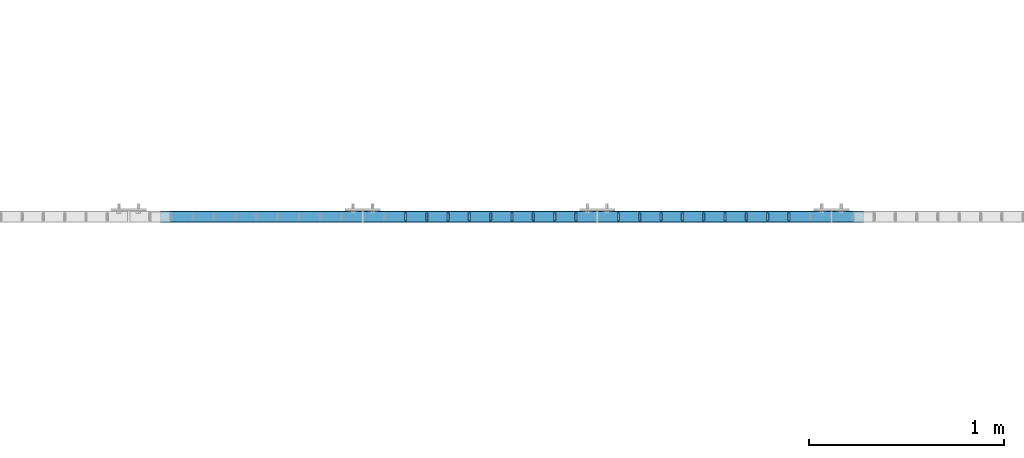
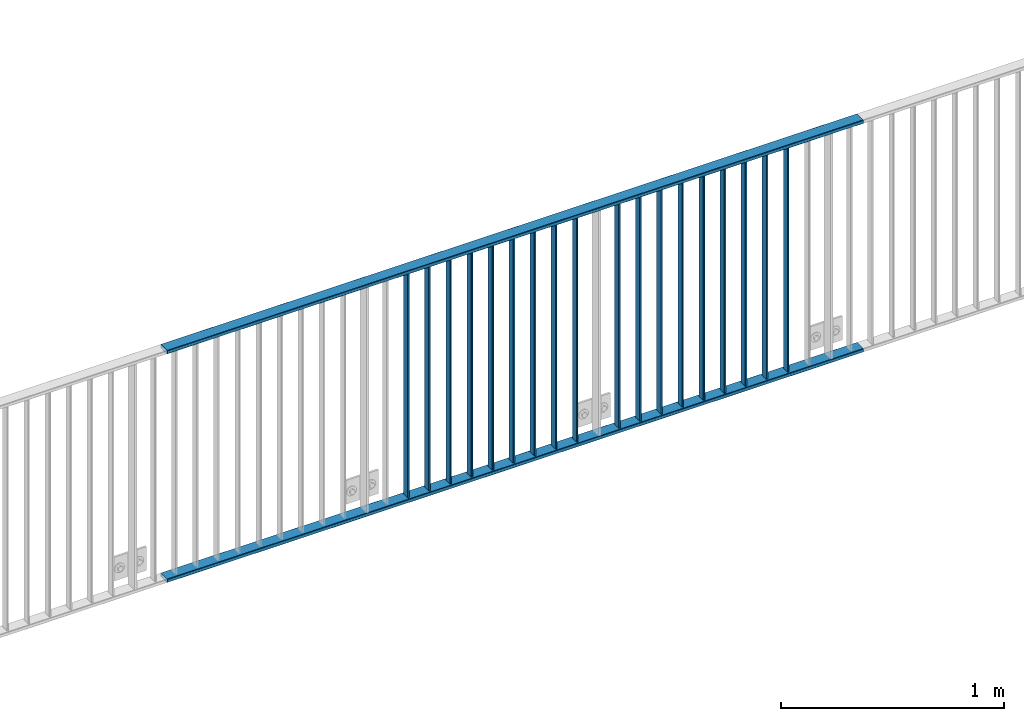
# One storey, part 7 of 156: 20 beams, 1 element without a shape of its own.
"""IFC2X3 building model written with IfcOpenShell, lengths in millimetres."""

from ifc_helpers import new_model, si_unit, frame, origin_with_axes, origin_2d_with_axis, place, context, subcontext, project, spatial, hollow_rectangle, extrude, clip, halfspace, material, type_object, element, aggregate, save


model = new_model("IFC2X3")

# Units and contexts
model_context = context("Model", 3, precision=1e-05, world=origin_with_axes())
body_context = subcontext(model_context, "Body", "Model", "MODEL_VIEW")
ifc_project = project(units=[si_unit("LENGTHUNIT", "METRE", prefix="MILLI"), si_unit("AREAUNIT", "SQUARE_METRE"), si_unit("VOLUMEUNIT", "CUBIC_METRE"), si_unit("MASSUNIT", "GRAM", prefix="KILO"), si_unit("TIMEUNIT", "SECOND"), si_unit("PLANEANGLEUNIT", "RADIAN"), si_unit("SOLIDANGLEUNIT", "STERADIAN"), si_unit("THERMODYNAMICTEMPERATUREUNIT", "DEGREE_CELSIUS"), si_unit("LUMINOUSINTENSITYUNIT", "LUMEN")], contexts=[model_context])

# Site, building, storey
site_placement = place(None, origin_with_axes())
site = spatial("IfcSite", under=ifc_project, at=site_placement, CompositionType="ELEMENT")
building_placement = place(site_placement, origin_with_axes())
building = spatial("IfcBuilding", under=site, at=building_placement, Name="Undefined", CompositionType="ELEMENT")
storey_placement = place(building_placement, origin_with_axes())
storey = spatial("IfcBuildingStorey", under=building, at=storey_placement, Name="Undefined", CompositionType="ELEMENT", Elevation=0.0)

# Assembly, beams
assembly_placement = place(storey_placement, origin_with_axes())
assembly = element("IfcElementAssembly", 1, at=assembly_placement, inside=storey, AssemblyPlace="NOTDEFINED", PredefinedType="RIGID_FRAME")
ifc_material = material(Name="STEEL/S235JR")
beam_type_1 = type_object("IfcBeamType", Name="K60/20/2", PredefinedType="NOTDEFINED")
beam_1_placement = place(assembly_placement, frame((17963.649999999, 10879.9998016357, 2740.0), z_axis=(0.0, 1.0, 0.0), x_axis=(1.0, 0.0, 0.0)))
beam_1 = element("IfcBeam", 2, at=beam_1_placement, type_object=beam_type_1, material=ifc_material, ObjectType="K60/20/2", context=body_context, shape_type="SweptSolid", body=[
    extrude(hollow_rectangle(XDim=20.0, YDim=60.0, WallThickness=2.0, InnerFilletRadius=2.0, OuterFilletRadius=4.0, at=origin_2d_with_axis()), frame((3599.985, 0.0, 0.0), z_axis=(-1.0, 0.0, 0.0), x_axis=(0.0, -1.0, 0.0)), (0.0, 0.0, 1.0), 3599.98),
])
beam_2_placement = place(assembly_placement, frame((17963.6457423371, 10879.9998016358, 3990.0), z_axis=(0.0, 1.0, 0.0), x_axis=(1.0, 0.0, 0.0)))
beam_2 = element("IfcBeam", 3, at=beam_2_placement, type_object=beam_type_1, material=ifc_material, ObjectType="K60/20/2", context=body_context, shape_type="SweptSolid", body=[
    extrude(hollow_rectangle(XDim=20.0, YDim=60.0, WallThickness=2.0, InnerFilletRadius=2.0, OuterFilletRadius=4.0, at=origin_2d_with_axis()), frame((3599.98925766191, 0.0, 0.0), z_axis=(-1.0, 0.0, 0.0), x_axis=(0.0, -1.0, 0.0)), (0.0, 0.0, 1.0), 3599.99),
])
beam_type_2 = type_object("IfcBeamType", Name="K40/10/1.5", PredefinedType="NOTDEFINED")
beam_3_placement = place(assembly_placement, frame((21181.809999999, 10879.9998088346, 3980.00000000003), z_axis=(0.0, 1.0, 0.0), x_axis=(0.0, 0.0, -1.0)))
beam_3 = element("IfcBeam", 4, at=beam_3_placement, type_object=beam_type_2, material=ifc_material, ObjectType="K40/10/1.5", context=body_context, shape_type="Clipping", body=[
    clip(clip(extrude(hollow_rectangle(XDim=10.0, YDim=40.0, WallThickness=1.5, InnerFilletRadius=1.5, OuterFilletRadius=3.0, at=origin_2d_with_axis()), frame((1237.00000000003, 0.0, 0.0), z_axis=(-1.0, 0.0, 0.0), x_axis=(0.0, -1.0, 0.0)), (0.0, 0.0, 1.0), 1244.0), halfspace(frame((1237.00000000003, 4.28697690345871, 47.3348312091512), z_axis=(1.0, 0.0, 0.0), x_axis=(0.0, -0.763991285051099, -0.645226562043109)), False)), halfspace(frame((-6.99999999997453, -4.08341515816574, 47.1651964219527), z_axis=(-1.0, 0.0, 0.0), x_axis=(0.0, 0.763991285051099, -0.645226562043109)), False)),
])
beam_4_placement = place(assembly_placement, frame((21072.719999999, 10879.9998088346, 3980.00000000003), z_axis=(0.0, 1.0, 0.0), x_axis=(0.0, 0.0, -1.0)))
beam_4 = element("IfcBeam", 5, at=beam_4_placement, type_object=beam_type_2, material=ifc_material, ObjectType="K40/10/1.5", context=body_context, shape_type="Clipping", body=[
    clip(clip(extrude(hollow_rectangle(XDim=10.0, YDim=40.0, WallThickness=1.5, InnerFilletRadius=1.5, OuterFilletRadius=3.0, at=origin_2d_with_axis()), frame((1237.00000000003, 0.0, 0.0), z_axis=(-1.0, 0.0, 0.0), x_axis=(0.0, -1.0, 0.0)), (0.0, 0.0, 1.0), 1244.0), halfspace(frame((1237.00000000003, 4.28697690345871, 47.3348312091512), z_axis=(1.0, 0.0, 0.0), x_axis=(0.0, -0.763991285051099, -0.645226562043109)), False)), halfspace(frame((-6.99999999997453, -4.08341515816574, 47.1651964219527), z_axis=(-1.0, 0.0, 0.0), x_axis=(0.0, 0.763991285051099, -0.645226562043109)), False)),
])
beam_5_placement = place(assembly_placement, frame((20963.629999999, 10879.9998088346, 3980.00000000003), z_axis=(0.0, 1.0, 0.0), x_axis=(0.0, 0.0, -1.0)))
beam_5 = element("IfcBeam", 6, at=beam_5_placement, type_object=beam_type_2, material=ifc_material, ObjectType="K40/10/1.5", context=body_context, shape_type="Clipping", body=[
    clip(clip(extrude(hollow_rectangle(XDim=10.0, YDim=40.0, WallThickness=1.5, InnerFilletRadius=1.5, OuterFilletRadius=3.0, at=origin_2d_with_axis()), frame((1237.00000000003, 0.0, 0.0), z_axis=(-1.0, 0.0, 0.0), x_axis=(0.0, -1.0, 0.0)), (0.0, 0.0, 1.0), 1244.0), halfspace(frame((1237.00000000003, 4.28697690345871, 47.3348312091512), z_axis=(1.0, 0.0, 0.0), x_axis=(0.0, -0.763991285051099, -0.645226562043109)), False)), halfspace(frame((-6.99999999997453, -4.08341515816574, 47.1651964219527), z_axis=(-1.0, 0.0, 0.0), x_axis=(0.0, 0.763991285051099, -0.645226562043109)), False)),
])
beam_6_placement = place(assembly_placement, frame((20854.539999999, 10879.9998088346, 3980.00000000003), z_axis=(0.0, 1.0, 0.0), x_axis=(0.0, 0.0, -1.0)))
beam_6 = element("IfcBeam", 7, at=beam_6_placement, type_object=beam_type_2, material=ifc_material, ObjectType="K40/10/1.5", context=body_context, shape_type="Clipping", body=[
    clip(clip(extrude(hollow_rectangle(XDim=10.0, YDim=40.0, WallThickness=1.5, InnerFilletRadius=1.5, OuterFilletRadius=3.0, at=origin_2d_with_axis()), frame((1237.00000000003, 0.0, 0.0), z_axis=(-1.0, 0.0, 0.0), x_axis=(0.0, -1.0, 0.0)), (0.0, 0.0, 1.0), 1244.0), halfspace(frame((1237.00000000003, 4.28697690345871, 47.3348312091512), z_axis=(1.0, 0.0, 0.0), x_axis=(0.0, -0.763991285051099, -0.645226562043109)), False)), halfspace(frame((-6.99999999997453, -4.08341515816574, 47.1651964219527), z_axis=(-1.0, 0.0, 0.0), x_axis=(0.0, 0.763991285051099, -0.645226562043109)), False)),
])
beam_7_placement = place(assembly_placement, frame((20745.449999999, 10879.9998088346, 3980.00000000003), z_axis=(0.0, 1.0, 0.0), x_axis=(0.0, 0.0, -1.0)))
beam_7 = element("IfcBeam", 8, at=beam_7_placement, type_object=beam_type_2, material=ifc_material, ObjectType="K40/10/1.5", context=body_context, shape_type="Clipping", body=[
    clip(clip(extrude(hollow_rectangle(XDim=10.0, YDim=40.0, WallThickness=1.5, InnerFilletRadius=1.5, OuterFilletRadius=3.0, at=origin_2d_with_axis()), frame((1237.00000000003, 0.0, 0.0), z_axis=(-1.0, 0.0, 0.0), x_axis=(0.0, -1.0, 0.0)), (0.0, 0.0, 1.0), 1244.0), halfspace(frame((1237.00000000003, 4.28697690345871, 47.3348312091512), z_axis=(1.0, 0.0, 0.0), x_axis=(0.0, -0.763991285051099, -0.645226562043109)), False)), halfspace(frame((-6.99999999997453, -4.08341515816574, 47.1651964219527), z_axis=(-1.0, 0.0, 0.0), x_axis=(0.0, 0.763991285051099, -0.645226562043109)), False)),
])
beam_8_placement = place(assembly_placement, frame((20636.359999999, 10879.9998088346, 3980.00000000003), z_axis=(0.0, 1.0, 0.0), x_axis=(0.0, 0.0, -1.0)))
beam_8 = element("IfcBeam", 9, at=beam_8_placement, type_object=beam_type_2, material=ifc_material, ObjectType="K40/10/1.5", context=body_context, shape_type="Clipping", body=[
    clip(clip(extrude(hollow_rectangle(XDim=10.0, YDim=40.0, WallThickness=1.5, InnerFilletRadius=1.5, OuterFilletRadius=3.0, at=origin_2d_with_axis()), frame((1237.00000000003, 0.0, 0.0), z_axis=(-1.0, 0.0, 0.0), x_axis=(0.0, -1.0, 0.0)), (0.0, 0.0, 1.0), 1244.0), halfspace(frame((1237.00000000003, 4.28697690345871, 47.3348312091512), z_axis=(1.0, 0.0, 0.0), x_axis=(0.0, -0.763991285051099, -0.645226562043109)), False)), halfspace(frame((-6.99999999997453, -4.08341515816574, 47.1651964219527), z_axis=(-1.0, 0.0, 0.0), x_axis=(0.0, 0.763991285051099, -0.645226562043109)), False)),
])
beam_9_placement = place(assembly_placement, frame((20527.269999999, 10879.9998088346, 3980.00000000003), z_axis=(0.0, 1.0, 0.0), x_axis=(0.0, 0.0, -1.0)))
beam_9 = element("IfcBeam", 10, at=beam_9_placement, type_object=beam_type_2, material=ifc_material, ObjectType="K40/10/1.5", context=body_context, shape_type="Clipping", body=[
    clip(clip(extrude(hollow_rectangle(XDim=10.0, YDim=40.0, WallThickness=1.5, InnerFilletRadius=1.5, OuterFilletRadius=3.0, at=origin_2d_with_axis()), frame((1237.00000000003, 0.0, 0.0), z_axis=(-1.0, 0.0, 0.0), x_axis=(0.0, -1.0, 0.0)), (0.0, 0.0, 1.0), 1244.0), halfspace(frame((1237.00000000003, 4.28697690345871, 47.3348312091512), z_axis=(1.0, 0.0, 0.0), x_axis=(0.0, -0.763991285051099, -0.645226562043109)), False)), halfspace(frame((-6.99999999997453, -4.08341515816574, 47.1651964219527), z_axis=(-1.0, 0.0, 0.0), x_axis=(0.0, 0.763991285051099, -0.645226562043109)), False)),
])
beam_10_placement = place(assembly_placement, frame((20418.179999999, 10879.9998088346, 3980.00000000003), z_axis=(0.0, 1.0, 0.0), x_axis=(0.0, 0.0, -1.0)))
beam_10 = element("IfcBeam", 11, at=beam_10_placement, type_object=beam_type_2, material=ifc_material, ObjectType="K40/10/1.5", context=body_context, shape_type="Clipping", body=[
    clip(clip(extrude(hollow_rectangle(XDim=10.0, YDim=40.0, WallThickness=1.5, InnerFilletRadius=1.5, OuterFilletRadius=3.0, at=origin_2d_with_axis()), frame((1237.00000000003, 0.0, 0.0), z_axis=(-1.0, 0.0, 0.0), x_axis=(0.0, -1.0, 0.0)), (0.0, 0.0, 1.0), 1244.0), halfspace(frame((1237.00000000003, 4.28697690345871, 47.3348312091512), z_axis=(1.0, 0.0, 0.0), x_axis=(0.0, -0.763991285051099, -0.645226562043109)), False)), halfspace(frame((-6.99999999997453, -4.08341515816574, 47.1651964219527), z_axis=(-1.0, 0.0, 0.0), x_axis=(0.0, 0.763991285051099, -0.645226562043109)), False)),
])
beam_11_placement = place(assembly_placement, frame((20309.089999999, 10879.9998088346, 3980.00000000003), z_axis=(0.0, 1.0, 0.0), x_axis=(0.0, 0.0, -1.0)))
beam_11 = element("IfcBeam", 12, at=beam_11_placement, type_object=beam_type_2, material=ifc_material, ObjectType="K40/10/1.5", context=body_context, shape_type="Clipping", body=[
    clip(clip(extrude(hollow_rectangle(XDim=10.0, YDim=40.0, WallThickness=1.5, InnerFilletRadius=1.5, OuterFilletRadius=3.0, at=origin_2d_with_axis()), frame((1237.00000000003, 0.0, 0.0), z_axis=(-1.0, 0.0, 0.0), x_axis=(0.0, -1.0, 0.0)), (0.0, 0.0, 1.0), 1244.0), halfspace(frame((1237.00000000003, 4.20486777192855, 47.2664069333041), z_axis=(1.0, 0.0, 0.0), x_axis=(0.0, -0.763991285051099, -0.645226562043109)), False)), halfspace(frame((-6.99999999997453, -3.90376720472705, 47.0154897941757), z_axis=(-1.0, 0.0, 0.0), x_axis=(0.0, 0.761952806119621, -0.647632551101653)), False)),
])
beam_12_placement = place(assembly_placement, frame((20090.899999999, 10879.9998088346, 3980.00000000003), z_axis=(0.0, 1.0, 0.0), x_axis=(0.0, 0.0, -1.0)))
beam_12 = element("IfcBeam", 13, at=beam_12_placement, type_object=beam_type_2, material=ifc_material, ObjectType="K40/10/1.5", context=body_context, shape_type="Clipping", body=[
    clip(clip(extrude(hollow_rectangle(XDim=10.0, YDim=40.0, WallThickness=1.5, InnerFilletRadius=1.5, OuterFilletRadius=3.0, at=origin_2d_with_axis()), frame((1237.00000000003, 0.0, 0.0), z_axis=(-1.0, 0.0, 0.0), x_axis=(0.0, -1.0, 0.0)), (0.0, 0.0, 1.0), 1244.0), halfspace(frame((1237.00000000003, 4.28697690345871, 47.3348312091512), z_axis=(1.0, 0.0, 0.0), x_axis=(0.0, -0.763991285051099, -0.645226562043109)), False)), halfspace(frame((-6.99999999997453, -4.08341515816574, 47.1651964219527), z_axis=(-1.0, 0.0, 0.0), x_axis=(0.0, 0.763991285051099, -0.645226562043109)), False)),
])
beam_13_placement = place(assembly_placement, frame((19981.809999999, 10879.9998088346, 3980.00000000003), z_axis=(0.0, 1.0, 0.0), x_axis=(0.0, 0.0, -1.0)))
beam_13 = element("IfcBeam", 14, at=beam_13_placement, type_object=beam_type_2, material=ifc_material, ObjectType="K40/10/1.5", context=body_context, shape_type="Clipping", body=[
    clip(clip(extrude(hollow_rectangle(XDim=10.0, YDim=40.0, WallThickness=1.5, InnerFilletRadius=1.5, OuterFilletRadius=3.0, at=origin_2d_with_axis()), frame((1237.00000000003, 0.0, 0.0), z_axis=(-1.0, 0.0, 0.0), x_axis=(0.0, -1.0, 0.0)), (0.0, 0.0, 1.0), 1244.0), halfspace(frame((1237.00000000003, 4.28697690345871, 47.3348312091512), z_axis=(1.0, 0.0, 0.0), x_axis=(0.0, -0.763991285051099, -0.645226562043109)), False)), halfspace(frame((-6.99999999997453, -4.08341515816574, 47.1651964219527), z_axis=(-1.0, 0.0, 0.0), x_axis=(0.0, 0.763991285051099, -0.645226562043109)), False)),
])
beam_14_placement = place(assembly_placement, frame((19872.719999999, 10879.9998088346, 3980.00000000003), z_axis=(0.0, 1.0, 0.0), x_axis=(0.0, 0.0, -1.0)))
beam_14 = element("IfcBeam", 15, at=beam_14_placement, type_object=beam_type_2, material=ifc_material, ObjectType="K40/10/1.5", context=body_context, shape_type="Clipping", body=[
    clip(clip(extrude(hollow_rectangle(XDim=10.0, YDim=40.0, WallThickness=1.5, InnerFilletRadius=1.5, OuterFilletRadius=3.0, at=origin_2d_with_axis()), frame((1237.00000000003, 0.0, 0.0), z_axis=(-1.0, 0.0, 0.0), x_axis=(0.0, -1.0, 0.0)), (0.0, 0.0, 1.0), 1244.0), halfspace(frame((1237.00000000003, 4.28697690345871, 47.3348312091512), z_axis=(1.0, 0.0, 0.0), x_axis=(0.0, -0.763991285051099, -0.645226562043109)), False)), halfspace(frame((-6.99999999997453, -4.08341515816574, 47.1651964219527), z_axis=(-1.0, 0.0, 0.0), x_axis=(0.0, 0.763991285051099, -0.645226562043109)), False)),
])
beam_15_placement = place(assembly_placement, frame((19763.629999999, 10879.9998088346, 3980.00000000003), z_axis=(0.0, 1.0, 0.0), x_axis=(0.0, 0.0, -1.0)))
beam_15 = element("IfcBeam", 16, at=beam_15_placement, type_object=beam_type_2, material=ifc_material, ObjectType="K40/10/1.5", context=body_context, shape_type="Clipping", body=[
    clip(clip(extrude(hollow_rectangle(XDim=10.0, YDim=40.0, WallThickness=1.5, InnerFilletRadius=1.5, OuterFilletRadius=3.0, at=origin_2d_with_axis()), frame((1237.00000000003, 0.0, 0.0), z_axis=(-1.0, 0.0, 0.0), x_axis=(0.0, -1.0, 0.0)), (0.0, 0.0, 1.0), 1244.0), halfspace(frame((1237.00000000003, 4.28697690345871, 47.3348312091512), z_axis=(1.0, 0.0, 0.0), x_axis=(0.0, -0.763991285051099, -0.645226562043109)), False)), halfspace(frame((-6.99999999997453, -4.08341515816574, 47.1651964219527), z_axis=(-1.0, 0.0, 0.0), x_axis=(0.0, 0.763991285051099, -0.645226562043109)), False)),
])
beam_16_placement = place(assembly_placement, frame((19654.539999999, 10879.9998088346, 3980.00000000003), z_axis=(0.0, 1.0, 0.0), x_axis=(0.0, 0.0, -1.0)))
beam_16 = element("IfcBeam", 17, at=beam_16_placement, type_object=beam_type_2, material=ifc_material, ObjectType="K40/10/1.5", context=body_context, shape_type="Clipping", body=[
    clip(clip(extrude(hollow_rectangle(XDim=10.0, YDim=40.0, WallThickness=1.5, InnerFilletRadius=1.5, OuterFilletRadius=3.0, at=origin_2d_with_axis()), frame((1237.00000000003, 0.0, 0.0), z_axis=(-1.0, 0.0, 0.0), x_axis=(0.0, -1.0, 0.0)), (0.0, 0.0, 1.0), 1244.0), halfspace(frame((1237.00000000003, 4.28697690345871, 47.3348312091512), z_axis=(1.0, 0.0, 0.0), x_axis=(0.0, -0.763991285051099, -0.645226562043109)), False)), halfspace(frame((-6.99999999997453, -4.08341515816574, 47.1651964219527), z_axis=(-1.0, 0.0, 0.0), x_axis=(0.0, 0.763991285051099, -0.645226562043109)), False)),
])
beam_17_placement = place(assembly_placement, frame((19545.449999999, 10879.9998088346, 3980.00000000003), z_axis=(0.0, 1.0, 0.0), x_axis=(0.0, 0.0, -1.0)))
beam_17 = element("IfcBeam", 18, at=beam_17_placement, type_object=beam_type_2, material=ifc_material, ObjectType="K40/10/1.5", context=body_context, shape_type="Clipping", body=[
    clip(clip(extrude(hollow_rectangle(XDim=10.0, YDim=40.0, WallThickness=1.5, InnerFilletRadius=1.5, OuterFilletRadius=3.0, at=origin_2d_with_axis()), frame((1237.00000000003, 0.0, 0.0), z_axis=(-1.0, 0.0, 0.0), x_axis=(0.0, -1.0, 0.0)), (0.0, 0.0, 1.0), 1244.0), halfspace(frame((1237.00000000003, 4.28697690345871, 47.3348312091512), z_axis=(1.0, 0.0, 0.0), x_axis=(0.0, -0.763991285051099, -0.645226562043109)), False)), halfspace(frame((-6.99999999997453, -4.08341515816574, 47.1651964219527), z_axis=(-1.0, 0.0, 0.0), x_axis=(0.0, 0.763991285051099, -0.645226562043109)), False)),
])
beam_18_placement = place(assembly_placement, frame((19436.359999999, 10879.9998088346, 3980.00000000003), z_axis=(0.0, 1.0, 0.0), x_axis=(0.0, 0.0, -1.0)))
beam_18 = element("IfcBeam", 19, at=beam_18_placement, type_object=beam_type_2, material=ifc_material, ObjectType="K40/10/1.5", context=body_context, shape_type="Clipping", body=[
    clip(clip(extrude(hollow_rectangle(XDim=10.0, YDim=40.0, WallThickness=1.5, InnerFilletRadius=1.5, OuterFilletRadius=3.0, at=origin_2d_with_axis()), frame((1237.00000000003, 0.0, 0.0), z_axis=(-1.0, 0.0, 0.0), x_axis=(0.0, -1.0, 0.0)), (0.0, 0.0, 1.0), 1244.0), halfspace(frame((1237.00000000003, 4.28697690345871, 47.3348312091512), z_axis=(1.0, 0.0, 0.0), x_axis=(0.0, -0.763991285051099, -0.645226562043109)), False)), halfspace(frame((-6.99999999997453, -4.08341515816574, 47.1651964219527), z_axis=(-1.0, 0.0, 0.0), x_axis=(0.0, 0.763991285051099, -0.645226562043109)), False)),
])
beam_19_placement = place(assembly_placement, frame((19327.269999999, 10879.9998088346, 3980.00000000003), z_axis=(0.0, 1.0, 0.0), x_axis=(0.0, 0.0, -1.0)))
beam_19 = element("IfcBeam", 20, at=beam_19_placement, type_object=beam_type_2, material=ifc_material, ObjectType="K40/10/1.5", context=body_context, shape_type="Clipping", body=[
    clip(clip(extrude(hollow_rectangle(XDim=10.0, YDim=40.0, WallThickness=1.5, InnerFilletRadius=1.5, OuterFilletRadius=3.0, at=origin_2d_with_axis()), frame((1237.00000000003, 0.0, 0.0), z_axis=(-1.0, 0.0, 0.0), x_axis=(0.0, -1.0, 0.0)), (0.0, 0.0, 1.0), 1244.0), halfspace(frame((1237.00000000003, 4.28697690345871, 47.3348312091512), z_axis=(1.0, 0.0, 0.0), x_axis=(0.0, -0.763991285051099, -0.645226562043109)), False)), halfspace(frame((-6.99999999997453, -4.08341515816574, 47.1651964219527), z_axis=(-1.0, 0.0, 0.0), x_axis=(0.0, 0.763991285051099, -0.645226562043109)), False)),
])
beam_20_placement = place(assembly_placement, frame((19218.179999999, 10879.9998088346, 3980.00000000003), z_axis=(0.0, 1.0, 0.0), x_axis=(0.0, 0.0, -1.0)))
beam_20 = element("IfcBeam", 21, at=beam_20_placement, type_object=beam_type_2, material=ifc_material, ObjectType="K40/10/1.5", context=body_context, shape_type="Clipping", body=[
    clip(clip(extrude(hollow_rectangle(XDim=10.0, YDim=40.0, WallThickness=1.5, InnerFilletRadius=1.5, OuterFilletRadius=3.0, at=origin_2d_with_axis()), frame((1237.00000000003, 0.0, 0.0), z_axis=(-1.0, 0.0, 0.0), x_axis=(0.0, -1.0, 0.0)), (0.0, 0.0, 1.0), 1244.0), halfspace(frame((1237.00000000003, 4.28697690345871, 47.3348312091512), z_axis=(1.0, 0.0, 0.0), x_axis=(0.0, -0.763991285051099, -0.645226562043109)), False)), halfspace(frame((-6.99999999997453, -4.08341515816574, 47.1651964219527), z_axis=(-1.0, 0.0, 0.0), x_axis=(0.0, 0.763991285051099, -0.645226562043109)), False)),
])
aggregate(assembly, [beam_1, beam_2, beam_3, beam_4, beam_5, beam_6, beam_7, beam_8, beam_9, beam_10, beam_11, beam_12, beam_13, beam_14, beam_15, beam_16, beam_17, beam_18, beam_19, beam_20])

save(model, "model.ifc")
